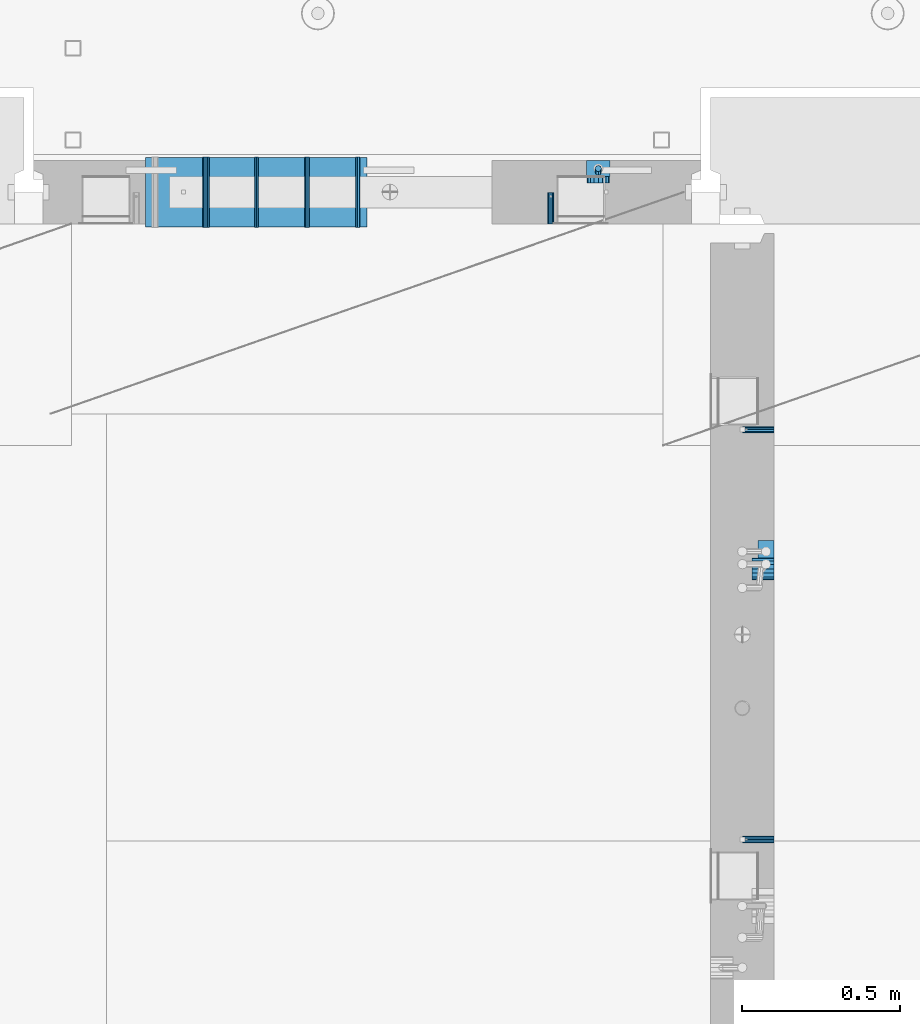
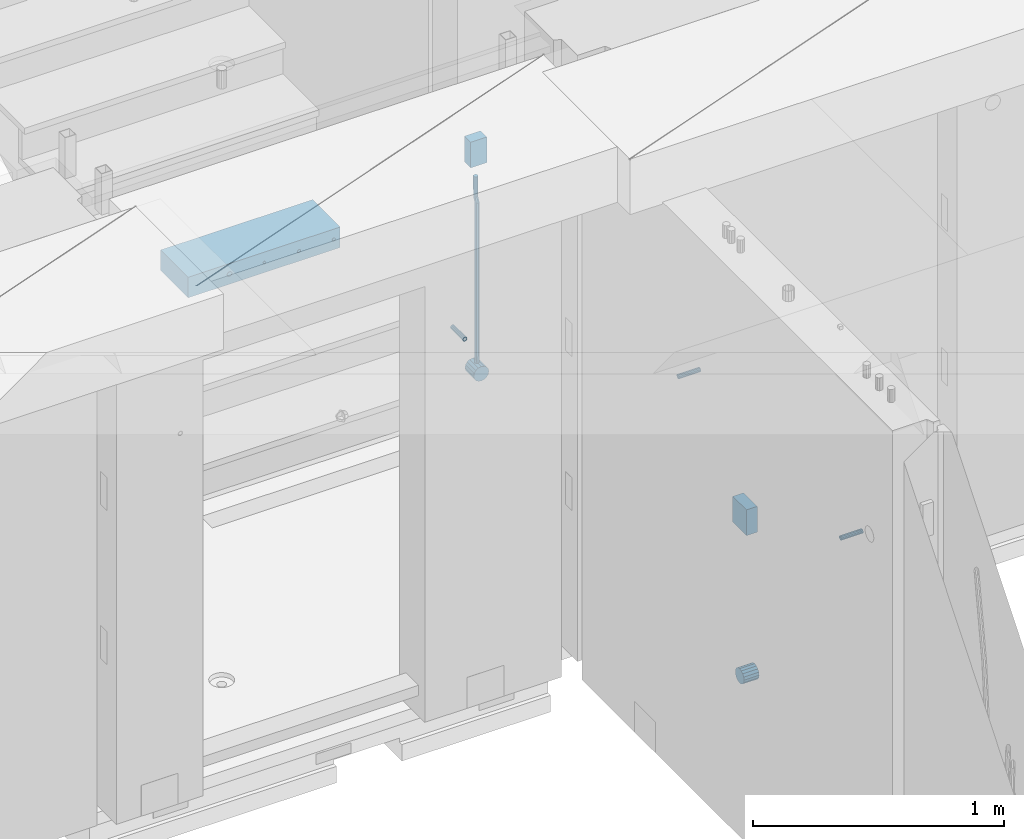
# One storey, part 148 of 352: 13 beams, 5 elements without a shape of their own.
"""IFC2X3 building model written with IfcOpenShell, lengths in millimetres."""

from ifc_helpers import new_model, si_unit, frame, origin_with_axes, place, context, subcontext, project, spatial, faceted_brep, material, type_object, element, aggregate, save


model = new_model("IFC2X3")

# Units and contexts
model_context = context("Model", 3, precision=1e-05, world=origin_with_axes())
body_context = subcontext(model_context, "Body", "Model", "MODEL_VIEW")
ifc_project = project(units=[si_unit("LENGTHUNIT", "METRE", prefix="MILLI"), si_unit("AREAUNIT", "SQUARE_METRE"), si_unit("VOLUMEUNIT", "CUBIC_METRE"), si_unit("MASSUNIT", "GRAM", prefix="KILO"), si_unit("TIMEUNIT", "SECOND"), si_unit("PLANEANGLEUNIT", "RADIAN"), si_unit("SOLIDANGLEUNIT", "STERADIAN"), si_unit("THERMODYNAMICTEMPERATUREUNIT", "DEGREE_CELSIUS"), si_unit("LUMINOUSINTENSITYUNIT", "LUMEN")], contexts=[model_context])

# Site, building, storey
site_placement = place(None, origin_with_axes())
site = spatial("IfcSite", under=ifc_project, at=site_placement, CompositionType="ELEMENT")
building_placement = place(site_placement, origin_with_axes())
building = spatial("IfcBuilding", under=site, at=building_placement, CompositionType="ELEMENT")
storey_placement = place(building_placement, origin_with_axes())
storey = spatial("IfcBuildingStorey", under=building, at=storey_placement, Name="6", CompositionType="ELEMENT", Elevation=0.0)

# Assemblies, beams
assembly_1_placement = place(storey_placement, origin_with_axes())
assembly_1 = element("IfcElementAssembly", 1, at=assembly_1_placement, inside=storey, AssemblyPlace="NOTDEFINED", PredefinedType="REINFORCEMENT_UNIT")
assembly_2_placement = place(assembly_1_placement, origin_with_axes())
assembly_2 = element("IfcElementAssembly", 2, at=assembly_2_placement, Name="Steel Assembly", AssemblyPlace="NOTDEFINED", PredefinedType="RIGID_FRAME")
ifc_material_1 = material(Name="STEEL/Steel_Undefined")
beam_type_1 = type_object("IfcBeamType", PredefinedType="NOTDEFINED")
beam_1_placement = place(assembly_2_placement, frame((21910.0, 13134.9999119588, 98555.0), z_axis=(0.0, -1.0, 0.0), x_axis=(-1.0, 3.00000001838171e-08, 0.0)))
beam_1 = element("IfcBeam", 3, at=beam_1_placement, type_object=beam_type_1, material=ifc_material_1, Name="M16", context=body_context, shape_type="Brep", body=[
    faceted_brep([(0.0, -8.49999999999272, -1.45519152283669e-11), (0.0, -7.36121593215648, 4.24999999998545), (100.000000000262, -7.36121593215648, 4.24999999998545), (100.000000000262, -8.49999999999272, -1.45519152283669e-11), (0.0, -4.24999999998545, 7.36121593216376), (100.000000000262, -4.24999999998545, 7.36121593216376), (0.0, 1.45519152283669e-11, 8.49999999998545), (100.000000000262, 1.45519152283669e-11, 8.49999999998545), (0.0, 4.25000000001455, 7.36121593216376), (100.000000000262, 4.25000000001455, 7.36121593216376), (0.0, 7.36121593217104, 4.24999999998545), (100.000000000262, 7.36121593217104, 4.24999999998545), (0.0, 8.50000000000728, 0.0), (100.000000000262, 8.50000000000728, 0.0), (0.0, 7.36121593217104, -4.25000000001455), (100.000000000262, 7.36121593217104, -4.25000000001455), (0.0, 4.25000000000728, -7.36121593219286), (100.000000000262, 4.25000000000728, -7.36121593219286), (0.0, 7.27595761418343e-12, -8.5), (100.000000000262, 7.27595761418343e-12, -8.5), (0.0, -4.24999999999272, -7.36121593217831), (100.000000000262, -4.24999999999272, -7.36121593217831), (0.0, -7.36121593215648, -4.25), (100.000000000262, -7.36121593215648, -4.25), (0.0, -10.4999999999927, -1.45519152283669e-11), (0.0, -9.09326673972828, -5.25000000001455), (100.000000000262, -9.09326673972828, -5.25000000001455), (100.000000000262, -10.4999999999927, -1.45519152283669e-11), (0.0, -5.24999999998545, -9.09326673974283), (100.000000000262, -5.24999999998545, -9.09326673974283), (0.0, 7.27595761418343e-12, -10.5), (100.000000000262, 7.27595761418343e-12, -10.5), (0.0, 5.25000000001455, -9.09326673975738), (100.000000000262, 5.25000000001455, -9.09326673975738), (0.0, 9.09326673975011, -5.25000000001455), (100.000000000262, 9.09326673975011, -5.25000000001455), (0.0, 10.5000000000073, -1.45519152283669e-11), (100.000000000262, 10.5000000000073, -1.45519152283669e-11), (0.0, 9.09326673975011, 5.25), (100.000000000262, 9.09326673975011, 5.25), (0.0, 5.25000000000728, 9.09326673972828), (100.000000000262, 5.25000000000728, 9.09326673972828), (0.0, 1.45519152283669e-11, 10.4999999999854), (100.000000000262, 1.45519152283669e-11, 10.4999999999854), (0.0, -5.24999999999272, 9.09326673972828), (100.000000000262, -5.24999999999272, 9.09326673972828), (0.0, -9.09326673972828, 5.24999999998545), (100.000000000262, -9.09326673972828, 5.24999999998545)], [[[0, 1, 2, 3]], [[1, 4, 5, 2]], [[4, 6, 7, 5]], [[6, 8, 9, 7]], [[8, 10, 11, 9]], [[10, 12, 13, 11]], [[12, 14, 15, 13]], [[14, 16, 17, 15]], [[16, 18, 19, 17]], [[18, 20, 21, 19]], [[20, 22, 23, 21]], [[22, 0, 3, 23]], [[24, 25, 26, 27]], [[25, 28, 29, 26]], [[28, 30, 31, 29]], [[30, 32, 33, 31]], [[32, 34, 35, 33]], [[34, 36, 37, 35]], [[36, 38, 39, 37]], [[38, 40, 41, 39]], [[40, 42, 43, 41]], [[42, 44, 45, 43]], [[44, 46, 47, 45]], [[46, 24, 27, 47]], [[29, 31, 33, 35, 37, 39, 41, 43, 45, 47, 27, 26], [5, 7, 9, 11, 13, 15, 17, 19, 21, 23, 3, 2]], [[46, 44, 42, 40, 38, 36, 34, 32, 30, 28, 25, 24], [22, 20, 18, 16, 14, 12, 10, 8, 6, 4, 1, 0]]]),
])
aggregate(assembly_2, [beam_1])
assembly_3_placement = place(assembly_1_placement, origin_with_axes())
assembly_3 = element("IfcElementAssembly", 4, at=assembly_3_placement, Name="Steel Assembly", AssemblyPlace="NOTDEFINED", PredefinedType="RIGID_FRAME")
beam_2_placement = place(assembly_3_placement, frame((21910.0, 14429.9999119589, 98555.0), z_axis=(0.0, 1.0, 0.0), x_axis=(-1.0, 3.00000001838171e-08, 0.0)))
beam_2 = element("IfcBeam", 5, at=beam_2_placement, type_object=beam_type_1, material=ifc_material_1, Name="M16", context=body_context, shape_type="Brep", body=[
    faceted_brep([(0.0, -8.49999999999272, -1.45519152283669e-11), (0.0, -7.36121593215648, 4.24999999998545), (100.000000000262, -7.36121593215648, 4.24999999998545), (100.000000000262, -8.49999999999272, -1.45519152283669e-11), (0.0, -4.24999999998545, 7.36121593216376), (100.000000000262, -4.24999999998545, 7.36121593216376), (0.0, 1.45519152283669e-11, 8.49999999998545), (100.000000000262, 1.45519152283669e-11, 8.49999999998545), (0.0, 4.25000000001455, 7.36121593216376), (100.000000000262, 4.25000000001455, 7.36121593216376), (0.0, 7.36121593217104, 4.24999999998545), (100.000000000262, 7.36121593217104, 4.24999999998545), (0.0, 8.50000000000728, 0.0), (100.000000000262, 8.50000000000728, 0.0), (0.0, 7.36121593217104, -4.25000000001455), (100.000000000262, 7.36121593217104, -4.25000000001455), (0.0, 4.25000000000728, -7.36121593219286), (100.000000000262, 4.25000000000728, -7.36121593219286), (0.0, 7.27595761418343e-12, -8.5), (100.000000000262, 7.27595761418343e-12, -8.5), (0.0, -4.24999999999272, -7.36121593217831), (100.000000000262, -4.24999999999272, -7.36121593217831), (0.0, -7.36121593215648, -4.25), (100.000000000262, -7.36121593215648, -4.25), (0.0, -10.4999999999927, -1.45519152283669e-11), (0.0, -9.09326673972828, -5.25000000001455), (100.000000000262, -9.09326673972828, -5.25000000001455), (100.000000000262, -10.4999999999927, -1.45519152283669e-11), (0.0, -5.24999999998545, -9.09326673974283), (100.000000000262, -5.24999999998545, -9.09326673974283), (0.0, 7.27595761418343e-12, -10.5), (100.000000000262, 7.27595761418343e-12, -10.5), (0.0, 5.25000000001455, -9.09326673975738), (100.000000000262, 5.25000000001455, -9.09326673975738), (0.0, 9.09326673975011, -5.25000000001455), (100.000000000262, 9.09326673975011, -5.25000000001455), (0.0, 10.5000000000073, -1.45519152283669e-11), (100.000000000262, 10.5000000000073, -1.45519152283669e-11), (0.0, 9.09326673975011, 5.25), (100.000000000262, 9.09326673975011, 5.25), (0.0, 5.25000000000728, 9.09326673972828), (100.000000000262, 5.25000000000728, 9.09326673972828), (0.0, 1.45519152283669e-11, 10.4999999999854), (100.000000000262, 1.45519152283669e-11, 10.4999999999854), (0.0, -5.24999999999272, 9.09326673972828), (100.000000000262, -5.24999999999272, 9.09326673972828), (0.0, -9.09326673972828, 5.24999999998545), (100.000000000262, -9.09326673972828, 5.24999999998545)], [[[0, 1, 2, 3]], [[1, 4, 5, 2]], [[4, 6, 7, 5]], [[6, 8, 9, 7]], [[8, 10, 11, 9]], [[10, 12, 13, 11]], [[12, 14, 15, 13]], [[14, 16, 17, 15]], [[16, 18, 19, 17]], [[18, 20, 21, 19]], [[20, 22, 23, 21]], [[22, 0, 3, 23]], [[24, 25, 26, 27]], [[25, 28, 29, 26]], [[28, 30, 31, 29]], [[30, 32, 33, 31]], [[32, 34, 35, 33]], [[34, 36, 37, 35]], [[36, 38, 39, 37]], [[38, 40, 41, 39]], [[40, 42, 43, 41]], [[42, 44, 45, 43]], [[44, 46, 47, 45]], [[46, 24, 27, 47]], [[29, 31, 33, 35, 37, 39, 41, 43, 45, 47, 27, 26], [5, 7, 9, 11, 13, 15, 17, 19, 21, 23, 3, 2]], [[46, 44, 42, 40, 38, 36, 34, 32, 30, 28, 25, 24], [22, 20, 18, 16, 14, 12, 10, 8, 6, 4, 1, 0]]]),
])
aggregate(assembly_3, [beam_2])

assembly_4_placement = place(storey_placement, origin_with_axes())
assembly_4 = element("IfcElementAssembly", 6, at=assembly_4_placement, inside=storey, AssemblyPlace="NOTDEFINED", PredefinedType="REINFORCEMENT_UNIT")
assembly_5_placement = place(assembly_4_placement, origin_with_axes())
assembly_5 = element("IfcElementAssembly", 7, at=assembly_5_placement, Name="Steel Assembly", AssemblyPlace="NOTDEFINED", PredefinedType="RIGID_FRAME")
beam_3_placement = place(assembly_5_placement, frame((21205.004085231, 15080.0, 98555.0), z_axis=(1.0, 0.0, 0.0), x_axis=(0.0, 1.0, 0.0)))
beam_3 = element("IfcBeam", 8, at=beam_3_placement, type_object=beam_type_1, material=ifc_material_1, Name="M16", context=body_context, shape_type="Brep", body=[
    faceted_brep([(0.0, -8.49999999999272, -1.45519152283669e-11), (0.0, -7.36121593215648, 4.24999999998545), (100.000000000262, -7.36121593215648, 4.24999999998545), (100.000000000262, -8.49999999999272, -1.45519152283669e-11), (0.0, -4.24999999998545, 7.36121593216376), (100.000000000262, -4.24999999998545, 7.36121593216376), (0.0, 1.45519152283669e-11, 8.49999999998545), (100.000000000262, 1.45519152283669e-11, 8.49999999998545), (0.0, 4.25000000001455, 7.36121593216376), (100.000000000262, 4.25000000001455, 7.36121593216376), (0.0, 7.36121593217104, 4.24999999998545), (100.000000000262, 7.36121593217104, 4.24999999998545), (0.0, 8.50000000000728, 0.0), (100.000000000262, 8.50000000000728, 0.0), (0.0, 7.36121593217104, -4.25000000001455), (100.000000000262, 7.36121593217104, -4.25000000001455), (0.0, 4.25000000000728, -7.36121593219286), (100.000000000262, 4.25000000000728, -7.36121593219286), (0.0, 7.27595761418343e-12, -8.5), (100.000000000262, 7.27595761418343e-12, -8.5), (0.0, -4.24999999999272, -7.36121593217831), (100.000000000262, -4.24999999999272, -7.36121593217831), (0.0, -7.36121593215648, -4.25), (100.000000000262, -7.36121593215648, -4.25), (0.0, -10.4999999999927, -1.45519152283669e-11), (0.0, -9.09326673972828, -5.25000000001455), (100.000000000262, -9.09326673972828, -5.25000000001455), (100.000000000262, -10.4999999999927, -1.45519152283669e-11), (0.0, -5.24999999998545, -9.09326673974283), (100.000000000262, -5.24999999998545, -9.09326673974283), (0.0, 7.27595761418343e-12, -10.5), (100.000000000262, 7.27595761418343e-12, -10.5), (0.0, 5.25000000001455, -9.09326673975738), (100.000000000262, 5.25000000001455, -9.09326673975738), (0.0, 9.09326673975011, -5.25000000001455), (100.000000000262, 9.09326673975011, -5.25000000001455), (0.0, 10.5000000000073, -1.45519152283669e-11), (100.000000000262, 10.5000000000073, -1.45519152283669e-11), (0.0, 9.09326673975011, 5.25), (100.000000000262, 9.09326673975011, 5.25), (0.0, 5.25000000000728, 9.09326673972828), (100.000000000262, 5.25000000000728, 9.09326673972828), (0.0, 1.45519152283669e-11, 10.4999999999854), (100.000000000262, 1.45519152283669e-11, 10.4999999999854), (0.0, -5.24999999999272, 9.09326673972828), (100.000000000262, -5.24999999999272, 9.09326673972828), (0.0, -9.09326673972828, 5.24999999998545), (100.000000000262, -9.09326673972828, 5.24999999998545)], [[[0, 1, 2, 3]], [[1, 4, 5, 2]], [[4, 6, 7, 5]], [[6, 8, 9, 7]], [[8, 10, 11, 9]], [[10, 12, 13, 11]], [[12, 14, 15, 13]], [[14, 16, 17, 15]], [[16, 18, 19, 17]], [[18, 20, 21, 19]], [[20, 22, 23, 21]], [[22, 0, 3, 23]], [[24, 25, 26, 27]], [[25, 28, 29, 26]], [[28, 30, 31, 29]], [[30, 32, 33, 31]], [[32, 34, 35, 33]], [[34, 36, 37, 35]], [[36, 38, 39, 37]], [[38, 40, 41, 39]], [[40, 42, 43, 41]], [[42, 44, 45, 43]], [[44, 46, 47, 45]], [[46, 24, 27, 47]], [[29, 31, 33, 35, 37, 39, 41, 43, 45, 47, 27, 26], [5, 7, 9, 11, 13, 15, 17, 19, 21, 23, 3, 2]], [[46, 44, 42, 40, 38, 36, 34, 32, 30, 28, 25, 24], [22, 20, 18, 16, 14, 12, 10, 8, 6, 4, 1, 0]]]),
])
aggregate(assembly_5, [beam_3])
ifc_material_2 = material()
beam_type_2 = type_object("IfcBeamType", Name="D20", PredefinedType="NOTDEFINED")
beam_4_placement = place(assembly_4_placement, frame((21354.9999999958, 15245.0000022759, 98290.0), z_axis=(0.00020576299992186, -0.999642804629538, -0.0267249099901004), x_axis=(-4.30000201928125e-08, -0.0267249099948059, 0.999642825806181)))
beam_4 = element("IfcBeam", 9, at=beam_4_placement, type_object=beam_type_2, material=ifc_material_2, Name="JM20", ObjectType="D20", context=body_context, shape_type="Brep", body=[
    faceted_brep([(0.0, -10.0, 0.0), (-4.19531716033816e-08, -7.07106781186667, -7.07106781187031), (60.3581158964225, -7.07106779467358, -7.07106780560207), (60.3581159005553, -9.99999998281055, 6.26459950581193e-09), (0.0, 0.0, -10.0), (60.3581158930319, 1.71930878423154e-08, -9.9999999937354), (4.196772351861e-08, 7.07106781186303, -7.07106781186667), (60.3581158923917, 7.07106782905612, -7.07106780560207), (0.0, 10.0, 0.0), (60.3581158948509, 10.0000000171895, 6.26459950581193e-09), (4.196772351861e-08, 7.07106781185939, 7.07106781185939), (60.3581158989837, 7.07106782905612, 7.07106781813127), (0.0, 0.0, 10.0), (60.3581159023597, 1.71930878423154e-08, 10.0000000062646), (-4.19531716033816e-08, -7.07106781187031, 7.07106781185939), (60.358115903, -7.07106779467722, 7.07106781813127), (60.8972477222414, -7.07106779452079, -7.07106780554386), (60.991799419251, -9.99999998403655, 6.21366780251265e-09), (60.8581158930319, 1.7334969015792e-08, -9.99999999368447), (60.8972861483926, 7.07106782920528, -7.07106780554386), (60.9917724058905, 10.0000000159635, 6.21366780251265e-09), (61.0863241029147, 7.07106782926348, 7.07106781820403), (61.1254559321096, 1.7415004549548e-08, 10.0000000063446), (61.086285676749, -7.07106779446985, 7.07106781820403), (61.4361869218264, -7.07107072394501, -7.08547838249069), (61.6251751877571, -10.0000034255863, -0.0169367769813107), (61.35793724822, -2.69946758635342e-06, -10.0133646071736), (61.4362637644808, 7.07106489957732, -7.08547940969947), (61.6252838596702, 9.99999657411536, -0.0169382296771801), (61.8142721256008, 7.07106387247404, 7.0516033758322), (61.8925217992073, -4.15200702263974e-06, 9.97948960051872), (61.814195282961, -7.07107175104829, 7.05160440304098), (775.690073058257, -7.07495307777208, -26.1837562433175), (775.879061324187, -10.0038857794134, -19.1152146378081), (775.611823384636, -0.00388505329101463, -29.1116424680004), (775.690149900896, 7.06718254575026, -26.1837572705263), (775.8791699961, 9.99611422029193, -19.1152160905003), (776.068158262031, 7.06718151865061, -12.0466744849909), (776.146407935637, -0.00388650583045091, -9.11878826030807), (776.068081419377, -7.07495410487172, -12.0466734577822), (776.844979390982, -7.07495935530824, -26.2146370302071), (778.703176670489, -10.0039011299996, -19.1907280380728), (776.111644739809, -0.00388777008629404, -29.1250070814895), (776.932750209904, 7.0671757915552, -26.2169828873994), (778.827303353013, 9.99609819560283, -19.1940455811236), (780.685500632535, 7.06715642091513, -12.1701365889894), (781.418835283708, -0.00391516431045602, -9.25976653770704), (780.597729813613, -7.07497872594467, -12.1677907318008), (777.861329320964, -7.08852484077215, -26.7638283058368), (781.188477298943, -10.0370730804789, -20.5336763496562), (776.551501535956, -0.00975865254440578, -29.362686553719), (778.026273295982, 7.05258025600779, -26.8078751783723), (781.421743305415, 9.96146953432981, -20.595968034173), (784.74889128338, 7.01292129462308, -14.3658160779887), (786.058719068402, -0.0658448936046625, -11.7669578301065), (784.583947308391, -7.12818380215685, -14.3217692054532), (795.432392943592, -7.32305037289916, -36.2584664814858), (798.759540921557, -10.2715986126059, -30.0283145252979), (794.12256515857, -0.244284184671415, -38.8573247293643), (795.597336918581, 6.81805472388078, -36.3025133540177), (798.992806928029, 9.72694400219916, -30.0906062098184), (802.319954905994, 6.77839576249244, -23.8604542536341), (803.629782691016, -0.300370425735309, -21.2615960057519), (802.15501093099, -7.3627093342875, -23.8164073811022), (799.505846831846, -7.3774198158244, -38.4595837060842), (801.367995818946, -10.3064143349802, -31.4378100447575), (798.762755292832, -0.306218002893729, -41.3646815597422), (799.574014147365, 6.7649769840682, -38.4513366830724), (801.464398961049, 9.69395502388943, -31.4261469929661), (803.32654794812, 6.76496050473361, -24.4043733316357), (804.069639487148, -0.306241308189783, -21.4992754779851), (803.258380632629, -7.37743629515535, -24.4126203546512), (804.134608044958, -7.36363999659807, -38.5831936197719), (804.332044311042, -10.2975903644801, -31.5169642204455), (804.035512197443, -0.290521008897485, -41.5054892177468), (804.092805771987, 6.77842942390271, -38.5720098863276), (804.272926969657, 9.70231601001069, -31.5011480329304), (804.470363235741, 6.76836564212863, -24.434918633604), (804.569459083272, -0.304753345568315, -21.5126230356327), (804.512165508728, -7.37370377836123, -24.4461023670447), (901.742523775247, -7.07306129268909, -41.1897886639781), (901.939960041316, -10.0070116605639, -34.1235592646481), (901.643427927731, 5.76950078539085e-05, -44.1120842619457), (901.700721502275, 7.06900812780805, -41.1786049305338), (901.880842699946, 9.99289471391967, -34.1077430771329), (902.07827896603, 7.05894434603761, -27.0415136778065), (902.177374813546, -0.0141746416556998, -24.1192180798353), (902.120081238987, -7.08312507445589, -27.0526974112508)], [[[0, 1, 2, 3]], [[1, 4, 5, 2]], [[4, 6, 7, 5]], [[6, 8, 9, 7]], [[8, 10, 11, 9]], [[10, 12, 13, 11]], [[12, 14, 15, 13]], [[14, 0, 3, 15]], [[14, 12, 10, 8, 6, 4, 1, 0]], [[3, 2, 16, 17]], [[2, 5, 18, 16]], [[5, 7, 19, 18]], [[7, 9, 20, 19]], [[9, 11, 21, 20]], [[11, 13, 22, 21]], [[13, 15, 23, 22]], [[15, 3, 17, 23]], [[17, 16, 24, 25]], [[16, 18, 26, 24]], [[18, 19, 27, 26]], [[19, 20, 28, 27]], [[20, 21, 29, 28]], [[21, 22, 30, 29]], [[22, 23, 31, 30]], [[23, 17, 25, 31]], [[25, 24, 32, 33]], [[24, 26, 34, 32]], [[26, 27, 35, 34]], [[27, 28, 36, 35]], [[28, 29, 37, 36]], [[29, 30, 38, 37]], [[30, 31, 39, 38]], [[31, 25, 33, 39]], [[33, 32, 40, 41]], [[32, 34, 42, 40]], [[34, 35, 43, 42]], [[35, 36, 44, 43]], [[36, 37, 45, 44]], [[37, 38, 46, 45]], [[38, 39, 47, 46]], [[39, 33, 41, 47]], [[41, 40, 48, 49]], [[40, 42, 50, 48]], [[42, 43, 51, 50]], [[43, 44, 52, 51]], [[44, 45, 53, 52]], [[45, 46, 54, 53]], [[46, 47, 55, 54]], [[47, 41, 49, 55]], [[49, 48, 56, 57]], [[48, 50, 58, 56]], [[50, 51, 59, 58]], [[51, 52, 60, 59]], [[52, 53, 61, 60]], [[53, 54, 62, 61]], [[54, 55, 63, 62]], [[55, 49, 57, 63]], [[57, 56, 64, 65]], [[56, 58, 66, 64]], [[58, 59, 67, 66]], [[59, 60, 68, 67]], [[60, 61, 69, 68]], [[61, 62, 70, 69]], [[62, 63, 71, 70]], [[63, 57, 65, 71]], [[65, 64, 72, 73]], [[64, 66, 74, 72]], [[66, 67, 75, 74]], [[67, 68, 76, 75]], [[68, 69, 77, 76]], [[69, 70, 78, 77]], [[70, 71, 79, 78]], [[71, 65, 73, 79]], [[73, 72, 80, 81]], [[72, 74, 82, 80]], [[74, 75, 83, 82]], [[75, 76, 84, 83]], [[76, 77, 85, 84]], [[77, 78, 86, 85]], [[78, 79, 87, 86]], [[79, 73, 81, 87]], [[82, 83, 84, 85, 86, 87, 81, 80]]]),
])

# Beam
beam_type_3 = type_object("IfcBeamType", Name="D70", PredefinedType="NOTDEFINED")
beam_5_placement = place(assembly_1_placement, frame((21910.0000022791, 13990.0, 97355.0), z_axis=(0.0, 0.0, 1.0), x_axis=(-1.0, 3.00000001838171e-08, 0.0)))
beam_5 = element("IfcBeam", 10, at=beam_5_placement, type_object=beam_type_3, material=ifc_material_2, ObjectType="D70", context=body_context, shape_type="Brep", body=[
    faceted_brep([(0.0, -35.0, 0.0), (0.0, -32.3357836378964, -13.3939201327739), (70.0, -32.3357836378964, -13.3939201327739), (70.0, -35.0, 0.0), (0.0, -24.7487373415279, -24.7487373415352), (70.0, -24.7487373415279, -24.7487373415352), (0.0, -13.3939201327776, -32.3357836379), (70.0, -13.3939201327776, -32.3357836379), (0.0, 0.0, -35.0), (70.0, 0.0, -35.0), (0.0, 13.3939201327776, -32.3357836379), (70.0, 13.3939201327776, -32.3357836379), (0.0, 24.7487373415279, -24.7487373415352), (70.0, 24.7487373415279, -24.7487373415352), (0.0, 32.3357836378964, -13.3939201327739), (70.0, 32.3357836378964, -13.3939201327739), (0.0, 35.0, 0.0), (70.0, 35.0, 0.0), (0.0, 32.3357836378964, 13.3939201327739), (70.0, 32.3357836378964, 13.3939201327739), (0.0, 24.7487373415279, 24.7487373415352), (70.0, 24.7487373415279, 24.7487373415352), (0.0, 13.3939201327776, 32.3357836379), (70.0, 13.3939201327776, 32.3357836379), (0.0, 0.0, 35.0), (70.0, 0.0, 35.0), (0.0, -13.3939201327776, 32.3357836379), (70.0, -13.3939201327776, 32.3357836379), (0.0, -24.7487373415279, 24.7487373415352), (70.0, -24.7487373415279, 24.7487373415352), (0.0, -32.3357836378964, 13.3939201327739), (70.0, -32.3357836378964, 13.3939201327739)], [[[0, 1, 2, 3]], [[1, 4, 5, 2]], [[4, 6, 7, 5]], [[6, 8, 9, 7]], [[8, 10, 11, 9]], [[10, 12, 13, 11]], [[12, 14, 15, 13]], [[14, 16, 17, 15]], [[16, 18, 19, 17]], [[18, 20, 21, 19]], [[20, 22, 23, 21]], [[22, 24, 25, 23]], [[24, 26, 27, 25]], [[26, 28, 29, 27]], [[28, 30, 31, 29]], [[30, 0, 3, 31]], [[5, 7, 9, 11, 13, 15, 17, 19, 21, 23, 25, 27, 29, 31, 3, 2]], [[30, 28, 26, 24, 22, 20, 18, 16, 14, 12, 10, 8, 6, 4, 1, 0]]]),
])

beam_6_placement = place(assembly_4_placement, frame((21354.9999999996, 15280.0000022759, 98255.0), z_axis=(0.0, 0.0, 1.0), x_axis=(0.0, -1.0, 0.0)))
beam_6 = element("IfcBeam", 11, at=beam_6_placement, type_object=beam_type_3, material=ifc_material_2, ObjectType="D70", context=body_context, shape_type="Brep", body=[
    faceted_brep([(0.0, -35.0, 0.0), (0.0, -32.3357836378964, -13.3939201327739), (70.0, -32.3357836378964, -13.3939201327739), (70.0, -35.0, 0.0), (0.0, -24.7487373415279, -24.7487373415352), (70.0, -24.7487373415279, -24.7487373415352), (0.0, -13.3939201327776, -32.3357836379), (70.0, -13.3939201327776, -32.3357836379), (0.0, 0.0, -35.0), (70.0, 0.0, -35.0), (0.0, 13.3939201327776, -32.3357836379), (70.0, 13.3939201327776, -32.3357836379), (0.0, 24.7487373415279, -24.7487373415352), (70.0, 24.7487373415279, -24.7487373415352), (0.0, 32.3357836378964, -13.3939201327739), (70.0, 32.3357836378964, -13.3939201327739), (0.0, 35.0, 0.0), (70.0, 35.0, 0.0), (0.0, 32.3357836378964, 13.3939201327739), (70.0, 32.3357836378964, 13.3939201327739), (0.0, 24.7487373415279, 24.7487373415352), (70.0, 24.7487373415279, 24.7487373415352), (0.0, 13.3939201327776, 32.3357836379), (70.0, 13.3939201327776, 32.3357836379), (0.0, 0.0, 35.0), (70.0, 0.0, 35.0), (0.0, -13.3939201327776, 32.3357836379), (70.0, -13.3939201327776, 32.3357836379), (0.0, -24.7487373415279, 24.7487373415352), (70.0, -24.7487373415279, 24.7487373415352), (0.0, -32.3357836378964, 13.3939201327739), (70.0, -32.3357836378964, 13.3939201327739)], [[[0, 1, 2, 3]], [[1, 4, 5, 2]], [[4, 6, 7, 5]], [[6, 8, 9, 7]], [[8, 10, 11, 9]], [[10, 12, 13, 11]], [[12, 14, 15, 13]], [[14, 16, 17, 15]], [[16, 18, 19, 17]], [[18, 20, 21, 19]], [[20, 22, 23, 21]], [[22, 24, 25, 23]], [[24, 26, 27, 25]], [[26, 28, 29, 27]], [[28, 30, 31, 29]], [[30, 0, 3, 31]], [[5, 7, 9, 11, 13, 15, 17, 19, 21, 23, 25, 27, 29, 31, 3, 2]], [[30, 28, 26, 24, 22, 20, 18, 16, 14, 12, 10, 8, 6, 4, 1, 0]]]),
])

ifc_material_3 = material()
beam_type_4 = type_object("IfcBeamType", Name="D12", PredefinedType="NOTDEFINED")
beam_7_placement = place(assembly_4_placement, frame((20274.9991455079, 15068.9997314798, 99260.0), z_axis=(-1.0, 3.00000001838171e-08, 0.0), x_axis=(0.0, 1.0, 0.0)))
beam_7 = element("IfcBeam", 12, at=beam_7_placement, type_object=beam_type_4, material=ifc_material_3, Name="12", ObjectType="D12", context=body_context, shape_type="Brep", body=[
    faceted_brep([(0.0, -6.0, -1.45519152283669e-11), (0.0, -4.24264068712, -4.24264068713819), (222.000077784061, -4.24264068712364, -4.24264068712), (222.000077784061, -6.0, 0.0), (3.63797880709171e-12, 0.0, -6.0000000000291), (222.000077784061, 0.0, -6.0), (0.0, 4.24264068712, -4.24264068713819), (222.000077784061, 4.24264068712364, -4.24264068712), (0.0, 6.0, -1.45519152283669e-11), (222.000077784061, 6.0, 0.0), (0.0, 4.24264068712, 4.24264068709454), (222.000077784061, 4.24264068712364, 4.24264068712), (0.0, 0.0, 5.99999999998545), (222.000077784061, 0.0, 6.0), (0.0, -4.24264068712, 4.24264068709454), (222.000077784061, -4.24264068712364, 4.24264068712)], [[[0, 1, 2, 3]], [[1, 4, 5, 2]], [[4, 6, 7, 5]], [[6, 8, 9, 7]], [[8, 10, 11, 9]], [[10, 12, 13, 11]], [[12, 14, 15, 13]], [[14, 0, 3, 15]], [[5, 7, 9, 11, 13, 15, 3, 2]], [[14, 12, 10, 8, 6, 4, 1, 0]]]),
])

beam_type_5 = type_object("IfcBeamType", Name="D15", PredefinedType="NOTDEFINED")
beam_8_placement = place(assembly_4_placement, frame((20594.99899292, 15068.9997314793, 99260.0), z_axis=(-1.0, 3.00000001838171e-08, 0.0), x_axis=(0.0, 1.0, 0.0)))
beam_8 = element("IfcBeam", 13, at=beam_8_placement, type_object=beam_type_5, material=ifc_material_3, Name="15", ObjectType="D15", context=body_context, shape_type="Brep", body=[
    faceted_brep([(0.0, -7.5, 0.0), (0.0, -5.30330085889727, -5.30330085890091), (222.000077784061, -5.30330085889727, -5.30330085890091), (222.000077784061, -7.5, 0.0), (0.0, 1.45519152283669e-11, -7.5), (222.000077784061, 0.0, -7.5), (0.0, 5.30330085889727, -5.30330085890091), (222.000077784061, 5.30330085889727, -5.30330085890091), (0.0, 7.5, 0.0), (222.000077784061, 7.5, 0.0), (0.0, 5.30330085889727, 5.30330085890091), (222.000077784061, 5.30330085889727, 5.30330085890091), (0.0, 1.45519152283669e-11, 7.5), (222.000077784061, 0.0, 7.5), (0.0, -5.30330085889727, 5.30330085890091), (222.000077784061, -5.30330085889727, 5.30330085890091)], [[[0, 1, 2, 3]], [[1, 4, 5, 2]], [[4, 6, 7, 5]], [[6, 8, 9, 7]], [[8, 10, 11, 9]], [[10, 12, 13, 11]], [[12, 14, 15, 13]], [[14, 0, 3, 15]], [[5, 7, 9, 11, 13, 15, 3, 2]], [[14, 12, 10, 8, 6, 4, 1, 0]]]),
])

beam_9_placement = place(assembly_4_placement, frame((20434.9991455079, 15068.9997314796, 99260.0), z_axis=(-1.0, 3.00000001838171e-08, 0.0), x_axis=(0.0, 1.0, 0.0)))
beam_9 = element("IfcBeam", 14, at=beam_9_placement, type_object=beam_type_5, material=ifc_material_3, Name="15", ObjectType="D15", context=body_context, shape_type="Brep", body=[
    faceted_brep([(0.0, -7.5, 0.0), (0.0, -5.30330085889727, -5.30330085890091), (222.000077784061, -5.30330085889727, -5.30330085890091), (222.000077784061, -7.5, 0.0), (0.0, 1.45519152283669e-11, -7.5), (222.000077784061, 0.0, -7.5), (0.0, 5.30330085889727, -5.30330085890091), (222.000077784061, 5.30330085889727, -5.30330085890091), (0.0, 7.5, 0.0), (222.000077784061, 7.5, 0.0), (0.0, 5.30330085889727, 5.30330085890091), (222.000077784061, 5.30330085889727, 5.30330085890091), (0.0, 1.45519152283669e-11, 7.5), (222.000077784061, 0.0, 7.5), (0.0, -5.30330085889727, 5.30330085890091), (222.000077784061, -5.30330085889727, 5.30330085890091)], [[[0, 1, 2, 3]], [[1, 4, 5, 2]], [[4, 6, 7, 5]], [[6, 8, 9, 7]], [[8, 10, 11, 9]], [[10, 12, 13, 11]], [[12, 14, 15, 13]], [[14, 0, 3, 15]], [[5, 7, 9, 11, 13, 15, 3, 2]], [[14, 12, 10, 8, 6, 4, 1, 0]]]),
])

beam_type_6 = type_object("IfcBeamType", Name="D22", PredefinedType="NOTDEFINED")
beam_10_placement = place(assembly_4_placement, frame((20114.9991455079, 15068.9997314801, 99260.0), z_axis=(-1.0, 3.00000001838171e-08, 0.0), x_axis=(0.0, 1.0, 0.0)))
beam_10 = element("IfcBeam", 15, at=beam_10_placement, type_object=beam_type_6, material=ifc_material_3, Name="22", ObjectType="D22", context=body_context, shape_type="Brep", body=[
    faceted_brep([(0.0, -11.0, 0.0), (0.0, -9.52627944163396, -5.5), (222.000077784061, -9.52627944163396, -5.5), (222.000077784061, -11.0, 0.0), (0.0, -5.5, -9.52627944163032), (222.000077784061, -5.5, -9.52627944163032), (0.0, 0.0, -11.0), (222.000077784061, 0.0, -11.0), (0.0, 5.5, -9.52627944163032), (222.000077784061, 5.5, -9.52627944163032), (0.0, 9.52627944163396, -5.5), (222.000077784061, 9.52627944163396, -5.5), (0.0, 11.0, 0.0), (222.000077784061, 11.0, 0.0), (0.0, 9.52627944163396, 5.5), (222.000077784061, 9.52627944163396, 5.5), (0.0, 5.5, 9.52627944163032), (222.000077784061, 5.5, 9.52627944163032), (0.0, 0.0, 11.0), (222.000077784061, 0.0, 11.0), (0.0, -5.5, 9.52627944163032), (222.000077784061, -5.5, 9.52627944163032), (0.0, -9.52627944163396, 5.5), (222.000077784061, -9.52627944163396, 5.5)], [[[0, 1, 2, 3]], [[1, 4, 5, 2]], [[4, 6, 7, 5]], [[6, 8, 9, 7]], [[8, 10, 11, 9]], [[10, 12, 13, 11]], [[12, 14, 15, 13]], [[14, 16, 17, 15]], [[16, 18, 19, 17]], [[18, 20, 21, 19]], [[20, 22, 23, 21]], [[22, 0, 3, 23]], [[5, 7, 9, 11, 13, 15, 17, 19, 21, 23, 3, 2]], [[22, 20, 18, 16, 14, 12, 10, 8, 6, 4, 1, 0]]]),
])

beam_type_7 = type_object("IfcBeamType", PredefinedType="NOTDEFINED")
beam_11_placement = place(assembly_4_placement, frame((20274.9991455078, 15069.9997314811, 99260.0), z_axis=(-1.0, 3.00000001838171e-08, 0.0), x_axis=(0.0, 1.0, 0.0)))
beam_11 = element("IfcBeam", 16, at=beam_11_placement, type_object=beam_type_7, material=ifc_material_3, context=body_context, shape_type="Brep", body=[
    faceted_brep([(0.0, 50.0, -350.0), (0.0, 50.0, 350.0), (220.000077784061, 50.0, 350.0), (220.000077784061, 50.0, -350.0), (0.0, -50.0, 350.0), (220.000077784061, -50.0, 350.0), (0.0, -50.0, -350.0), (220.000077784061, -50.0, -350.0)], [[[0, 1, 2, 3]], [[1, 4, 5, 2]], [[4, 6, 7, 5]], [[6, 0, 3, 7]], [[5, 7, 3, 2]], [[6, 4, 1, 0]]]),
])

beam_type_8 = type_object("IfcBeamType", Name="125X50", PredefinedType="NOTDEFINED")
beam_12_placement = place(assembly_1_placement, frame((21885.0, 13970.0, 98105.0), z_axis=(0.0, 0.0, 1.0), x_axis=(0.0, 1.0, 0.0)))
beam_12 = element("IfcBeam", 17, at=beam_12_placement, type_object=beam_type_8, material=ifc_material_2, Name="WM2", ObjectType="125X50", context=body_context, shape_type="Brep", body=[
    faceted_brep([(0.0, 25.0, -62.5), (0.0, 25.0, 62.5), (110.0, 25.0, 62.5), (110.0, 25.0, -62.5), (0.0, -25.0, 62.5), (110.0, -25.0, 62.5), (0.0, -25.0, -62.5), (110.0, -25.0, -62.5)], [[[0, 1, 2, 3]], [[1, 4, 5, 2]], [[4, 6, 7, 5]], [[6, 0, 3, 7]], [[5, 7, 3, 2]], [[0, 6, 4, 1]]]),
])

aggregate(assembly_1, [assembly_2, assembly_3, beam_12, beam_5])

beam_13_placement = place(assembly_4_placement, frame((21392.4999999996, 15254.9999999967, 99320.0), z_axis=(0.0, 0.0, 1.0), x_axis=(-1.0, 3.00000001838171e-08, 0.0)))
beam_13 = element("IfcBeam", 18, at=beam_13_placement, type_object=beam_type_8, material=ifc_material_2, Name="WM1", ObjectType="125X50", context=body_context, shape_type="Brep", body=[
    faceted_brep([(0.0, 25.0, -62.5), (0.0, 25.0, 62.5), (75.0, 25.0, 62.5), (75.0, 25.0, -62.5), (0.0, -25.0, 62.5), (75.0, -25.0, 62.5), (0.0, -25.0, -62.5), (75.0, -25.0, -62.5)], [[[0, 1, 2, 3]], [[1, 4, 5, 2]], [[4, 6, 7, 5]], [[6, 0, 3, 7]], [[5, 7, 3, 2]], [[0, 6, 4, 1]]]),
])

aggregate(assembly_4, [assembly_5, beam_13, beam_4, beam_6, beam_10, beam_7, beam_11, beam_8, beam_9])

save(model, "model.ifc")
